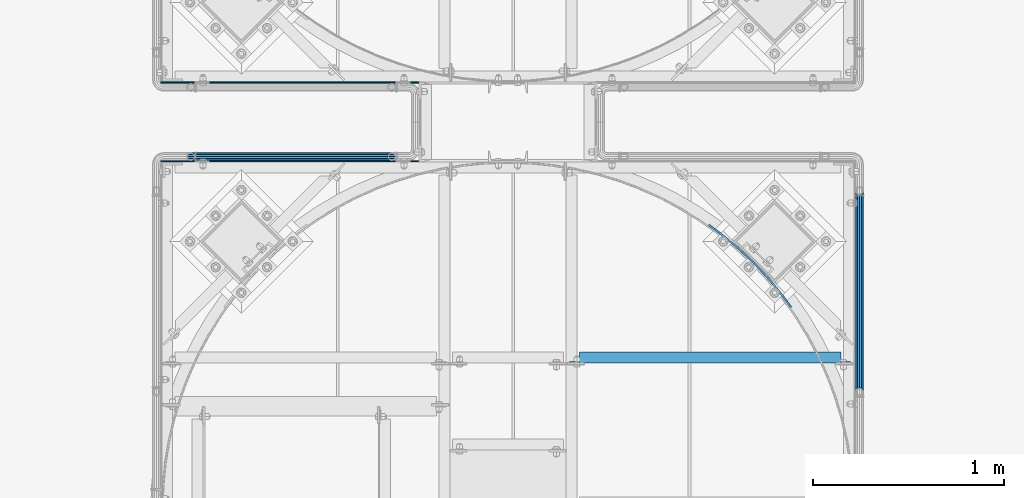
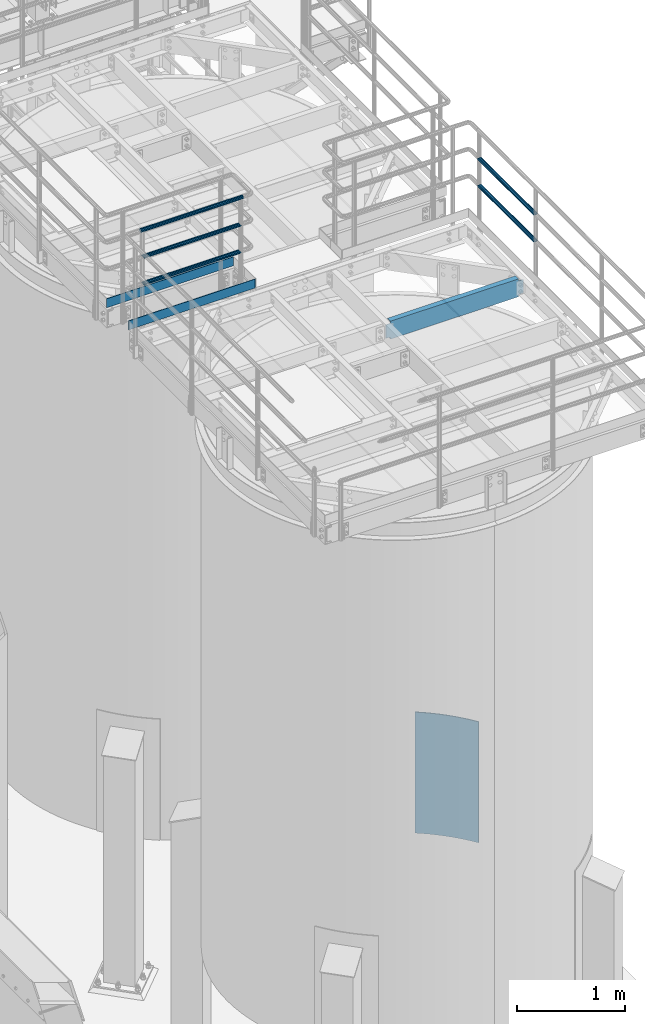
# One storey, part 925 of 1876: 9 beams, 5 elements without a shape of their own.
"""IFC2X3 building model written with IfcOpenShell, lengths in millimetres."""

from ifc_helpers import new_model, si_unit, frame, origin_with_axes, place, context, subcontext, project, spatial, faceted_brep, material, type_object, element, aggregate, save


model = new_model("IFC2X3")

# Units and contexts
model_context = context("Model", 3, precision=1e-05, world=origin_with_axes())
body_context = subcontext(model_context, "Body", "Model", "MODEL_VIEW")
ifc_project = project(units=[si_unit("LENGTHUNIT", "METRE", prefix="MILLI"), si_unit("AREAUNIT", "SQUARE_METRE"), si_unit("VOLUMEUNIT", "CUBIC_METRE"), si_unit("MASSUNIT", "GRAM", prefix="KILO"), si_unit("TIMEUNIT", "SECOND"), si_unit("PLANEANGLEUNIT", "RADIAN"), si_unit("SOLIDANGLEUNIT", "STERADIAN"), si_unit("THERMODYNAMICTEMPERATUREUNIT", "DEGREE_CELSIUS"), si_unit("LUMINOUSINTENSITYUNIT", "LUMEN")], contexts=[model_context])

# Site, building, storey
site_placement = place(None, origin_with_axes())
site = spatial("IfcSite", under=ifc_project, at=site_placement, CompositionType="ELEMENT")
building_placement = place(site_placement, origin_with_axes())
building = spatial("IfcBuilding", under=site, at=building_placement, Name="Undefined", CompositionType="ELEMENT")
storey_placement = place(building_placement, origin_with_axes())
storey = spatial("IfcBuildingStorey", under=building, at=storey_placement, Name="Undefined", CompositionType="ELEMENT", Elevation=0.0)

# Assembly, beams
assembly_1_placement = place(storey_placement, origin_with_axes())
assembly_1 = element("IfcElementAssembly", 1, at=assembly_1_placement, inside=storey, Name="HANDRAIL", AssemblyPlace="NOTDEFINED", PredefinedType="RIGID_FRAME")
ifc_material_1 = material()
beam_type_1 = type_object("IfcBeamType", Name="PIPE1-1/4STD", PredefinedType="NOTDEFINED")
beam_1_placement = place(assembly_1_placement, frame((4572.00143150122, -11745.4324531238, 8480.425), z_axis=(0.0, 0.0, 1.0), x_axis=(-1.0, 0.0, 0.0)))
beam_1 = element("IfcBeam", 2, at=beam_1_placement, type_object=beam_type_1, material=ifc_material_1, Name="RAIL", ObjectType="PIPE1-1/4STD", context=body_context, shape_type="Brep", body=[
    faceted_brep([(1035.84245243742, -10.5409999999993, 18.2575475625836), (1035.84245243742, -10.5409999999993, 13.3999612267253), (1035.36603877327, -8.76300000000083, 15.1779612267255), (1033.018, 0.0, 17.5259999999998), (1033.018, 0.0, 21.0820000000003), (1035.36603877327, 8.76300000000083, 15.1779612267255), (1035.84245243742, 10.5409999999993, 13.3999612267253), (1035.84245243742, 10.5409999999993, 18.2575475625836), (1054.1, 21.0820000000003, 0.0), (1043.559, 18.2575475625836, 10.5409999999993), (1043.559, 18.2575475625836, -10.5409999999993), (1040.47941366414, 15.1779612267255, 8.76300000000083), (1042.82745243742, 17.5259999999998, 0.0), (1040.47941366414, 15.1779612267255, -8.76300000000083), (1035.84245243742, 10.5409999999993, -13.3999612267253), (1035.84245243742, 10.5409999999993, -18.2575475625836), (1035.36603877327, 8.76300000000083, -15.1779612267255), (1033.018, 0.0, -17.5259999999998), (1033.018, 0.0, -21.0820000000003), (1035.84245243742, -10.5409999999993, -13.3999612267253), (1035.84245243742, -10.5409999999993, -18.2575475625836), (1035.36603877327, -8.76300000000083, -15.1779612267255), (1054.1, -21.0820000000003, 0.0), (1043.559, -18.2575475625836, -10.5409999999993), (1043.559, -18.2575475625836, 10.5409999999993), (1040.47941366414, -15.1779612267255, -8.76300000000083), (1042.82745243742, -17.5259999999998, 0.0), (1040.47941366414, -15.1779612267255, 8.76300000000083), (10.5409999957128, -18.2575475672238, -10.5409999999993), (18.2575475625817, -10.5410000000011, -18.2575475625836), (9.09494701772928e-13, 21.0820000000003, 0.0), (10.5409999957128, 18.2575475579433, -10.5409999999993), (10.5409999999983, 18.2575475625836, 10.5410000000011), (18.2575475625817, 10.5409999999993, 18.2575475625836), (21.0819999999985, 1.81898940354586e-12, 21.0820000000003), (18.2575475625817, 10.5409999999993, -18.2575475625836), (21.0819999999985, 0.0, -21.0819999999985), (21.0819999999985, 0.0, -17.5259999999998), (18.2575475625817, -10.5409999999974, -13.3999612267271), (18.7339612267233, -8.76300000000083, -15.1779612267255), (18.7339612267251, 8.76299999999901, -15.1779612267255), (18.2575475625817, 10.5410000000011, -13.3999612267235), (13.6205863358573, 15.1779612267255, -8.76299999999901), (11.2725475625839, 17.5259999999998, 0.0), (13.6205863358573, 15.1779612267255, 8.76300000000083), (18.2575475625817, 10.5410000000011, 13.3999612267253), (18.7339612267251, 8.76299999999901, 15.1779612267273), (21.0819999999985, 1.81898940354586e-12, 17.5259999999998), (18.7339612267233, -8.76300000000083, 15.1779612267273), (18.2575475625817, -10.5409999999974, 13.3999612267289), (18.2575475625817, -10.5410000000011, 18.2575475625836), (10.5409999999983, -18.2575475625836, 10.5410000000011), (9.09494701772928e-13, -21.0820000000003, 0.0), (13.6205863358537, -15.1779612267255, 8.76300000000083), (11.2725475625793, -17.5259999999998, 0.0), (13.6205863358537, -15.1779612267255, -8.76299999999901)], [[[0, 1, 2, 3, 4]], [[4, 3, 5, 6, 7]], [[8, 9, 10]], [[7, 6, 11, 12, 13, 14, 15, 10, 9]], [[16, 17, 18, 15, 14]], [[19, 20, 18, 17, 21]], [[22, 23, 24]], [[24, 23, 20, 19, 25, 26, 27, 1, 0]], [[28, 29, 20, 23]], [[30, 31, 32]], [[33, 34, 4, 7]], [[32, 33, 7, 9]], [[30, 32, 9, 8]], [[31, 30, 8, 10]], [[35, 31, 10, 15]], [[36, 35, 15, 18]], [[29, 36, 18, 20]], [[37, 36, 29, 38, 39]], [[40, 41, 35, 36, 37]], [[32, 31, 35, 41, 42, 43, 44, 45, 33]], [[33, 45, 46, 47, 34]], [[34, 47, 48, 49, 50]], [[34, 50, 0, 4]], [[50, 51, 24, 0]], [[51, 52, 22, 24]], [[52, 28, 23, 22]], [[51, 28, 52]], [[50, 49, 53, 54, 55, 38, 29, 28, 51]], [[55, 54, 26, 25]], [[21, 39, 38, 55, 25, 19]], [[37, 39, 21, 17]], [[40, 37, 17, 16]], [[42, 41, 40, 16, 14, 13]], [[43, 42, 13, 12]], [[44, 43, 12, 11]], [[5, 46, 45, 44, 11, 6]], [[47, 46, 5, 3]], [[48, 47, 3, 2]], [[53, 49, 48, 2, 1, 27]], [[54, 53, 27, 26]]]),
])
beam_2_placement = place(assembly_1_placement, frame((3517.90143150121, -11745.4324531238, 8785.225), z_axis=(0.0, 0.0, -1.0), x_axis=(1.0, 0.0, 0.0)))
beam_2 = element("IfcBeam", 3, at=beam_2_placement, type_object=beam_type_1, material=ifc_material_1, Name="RAIL", ObjectType="PIPE1-1/4STD", context=body_context, shape_type="Brep", body=[
    faceted_brep([(9.09494701772928e-13, 21.0820000000003, 0.0), (10.5409999957128, 18.2575475579433, -10.5409999999993), (10.5409999999983, 18.2575475625836, 10.5410000000011), (10.5409999999983, -18.2575475625836, 10.5410000000011), (10.5409999957128, -18.2575475672238, -10.5409999999993), (9.09494701772928e-13, -21.0820000000003, 0.0), (18.2575475625817, -10.5410000000011, 18.2575475625836), (18.2575475625817, -10.5409999999974, 13.3999612267289), (13.6205863358537, -15.1779612267255, 8.76300000000083), (11.2725475625793, -17.5259999999998, 0.0), (13.6205863358537, -15.1779612267255, -8.76299999999901), (18.2575475625817, -10.5409999999974, -13.3999612267271), (18.2575475625817, -10.5410000000011, -18.2575475625836), (21.0819999999985, 0.0, -17.5259999999998), (21.0819999999985, 0.0, -21.0819999999985), (18.7339612267233, -8.76300000000083, -15.1779612267255), (18.7339612267251, 8.76299999999901, -15.1779612267255), (18.2575475625817, 10.5410000000011, -13.3999612267235), (18.2575475625817, 10.5409999999993, -18.2575475625836), (13.6205863358573, 15.1779612267255, -8.76299999999901), (11.2725475625839, 17.5259999999998, 0.0), (13.6205863358573, 15.1779612267255, 8.76300000000083), (18.2575475625817, 10.5410000000011, 13.3999612267253), (18.2575475625817, 10.5409999999993, 18.2575475625836), (18.7339612267251, 8.76299999999901, 15.1779612267273), (21.0819999999985, 1.81898940354586e-12, 17.5259999999998), (21.0819999999985, 1.81898940354586e-12, 21.0820000000003), (18.7339612267233, -8.76300000000083, 15.1779612267273), (1054.1, 21.0820000000003, 0.0), (1043.559, 18.2575475625836, -10.5409999999993), (1035.84245243742, 10.5409999999993, -18.2575475625836), (1054.1, -21.0820000000003, 0.0), (1043.559, -18.2575475625836, -10.5409999999993), (1043.559, -18.2575475625836, 10.5409999999993), (1035.84245243742, -10.5409999999993, 18.2575475625836), (1035.84245243742, -10.5409999999993, -18.2575475625836), (1033.018, 0.0, -21.0820000000003), (1035.36603877327, 8.76300000000083, -15.1779612267255), (1033.018, 0.0, -17.5259999999998), (1035.84245243742, 10.5409999999993, -13.3999612267253), (1035.84245243742, -10.5409999999993, -13.3999612267253), (1035.36603877327, -8.76300000000083, -15.1779612267255), (1040.47941366414, -15.1779612267255, -8.76300000000083), (1042.82745243742, -17.5259999999998, 0.0), (1040.47941366414, -15.1779612267255, 8.76300000000083), (1035.84245243742, -10.5409999999993, 13.3999612267253), (1035.36603877327, -8.76300000000083, 15.1779612267255), (1033.018, 0.0, 17.5259999999998), (1033.018, 0.0, 21.0820000000003), (1035.84245243742, 10.5409999999993, 18.2575475625836), (1043.559, 18.2575475625836, 10.5409999999993), (1035.84245243742, 10.5409999999993, 13.3999612267253), (1040.47941366414, 15.1779612267255, 8.76300000000083), (1042.82745243742, 17.5259999999998, 0.0), (1040.47941366414, 15.1779612267255, -8.76300000000083), (1035.36603877327, 8.76300000000083, 15.1779612267255)], [[[0, 1, 2]], [[3, 4, 5]], [[6, 7, 8, 9, 10, 11, 12, 4, 3]], [[13, 14, 12, 11, 15]], [[16, 17, 18, 14, 13]], [[2, 1, 18, 17, 19, 20, 21, 22, 23]], [[23, 22, 24, 25, 26]], [[26, 25, 27, 7, 6]], [[1, 0, 28, 29]], [[18, 1, 29, 30]], [[31, 32, 33]], [[6, 3, 33, 34]], [[3, 5, 31, 33]], [[5, 4, 32, 31]], [[4, 12, 35, 32]], [[12, 14, 36, 35]], [[14, 18, 30, 36]], [[37, 38, 36, 30, 39]], [[40, 35, 36, 38, 41]], [[33, 32, 35, 40, 42, 43, 44, 45, 34]], [[34, 45, 46, 47, 48]], [[26, 6, 34, 48]], [[2, 23, 49, 50]], [[23, 26, 48, 49]], [[0, 2, 50, 28]], [[28, 50, 29]], [[49, 51, 52, 53, 54, 39, 30, 29, 50]], [[48, 47, 55, 51, 49]], [[25, 24, 55, 47]], [[55, 24, 22, 21, 52, 51]], [[21, 20, 53, 52]], [[20, 19, 54, 53]], [[19, 17, 16, 37, 39, 54]], [[16, 13, 38, 37]], [[13, 15, 41, 38]], [[41, 15, 11, 10, 42, 40]], [[10, 9, 43, 42]], [[9, 8, 44, 43]], [[8, 7, 27, 46, 45, 44]], [[27, 25, 47, 46]]]),
])
beam_3_placement = place(assembly_1_placement, frame((3496.81943150122, -11745.4324531238, 9090.025), z_axis=(0.0, 0.0, -1.0), x_axis=(1.0, 0.0, 0.0)))
beam_3 = element("IfcBeam", 4, at=beam_3_placement, type_object=beam_type_1, material=ifc_material_1, Name="HANDRAIL", ObjectType="PIPE1-1/4STD", context=body_context, shape_type="Brep", body=[
    faceted_brep([(0.0, -17.5259999999998, 0.0), (0.0, -15.1779612267264, 8.76300000000083), (1096.264, -15.1779612267255, 8.76300000000083), (1096.264, -17.5259999999998, 0.0), (0.0, -8.76299999999992, 15.1779612267255), (1096.264, -8.76300000000083, 15.1779612267255), (0.0, 0.0, 17.5259999999998), (1096.264, 0.0, 17.5259999999998), (0.0, 8.76299999999992, 15.1779612267255), (1096.264, 8.76300000000083, 15.1779612267255), (0.0, 15.1779612267264, 8.76300000000083), (1096.264, 15.1779612267255, 8.76300000000083), (0.0, 17.5259999999998, 0.0), (1096.264, 17.5259999999998, 0.0), (0.0, 15.1779612267264, -8.76300000000083), (1096.264, 15.1779612267255, -8.76300000000083), (0.0, 8.76299999999992, -15.1779612267255), (1096.264, 8.76300000000083, -15.1779612267255), (0.0, 0.0, -17.5259999999998), (1096.264, 0.0, -17.5259999999998), (0.0, -8.76299999999992, -15.1779612267255), (1096.264, -8.76300000000083, -15.1779612267255), (0.0, -15.1779612267264, -8.76300000000083), (1096.264, -15.1779612267255, -8.76300000000083), (9.09494701772928e-13, -21.0820000000003, 0.0), (0.0, -18.2575475625836, -10.5409999999993), (1096.264, -18.2575475625836, -10.5409999999993), (1096.264, -21.0820000000003, 0.0), (0.0, -10.5410000000002, -18.2575475625836), (1096.264, -10.5409999999993, -18.2575475625836), (-4.28826751885936e-09, 0.0, -21.0820000000003), (1096.264, 0.0, -21.0820000000003), (0.0, 10.5410000000002, -18.2575475625836), (1096.264, 10.5409999999993, -18.2575475625836), (0.0, 18.2575475625836, -10.5409999999993), (1096.264, 18.2575475625836, -10.5409999999993), (9.09494701772928e-13, 21.0820000000003, 0.0), (1096.264, 21.0820000000003, 0.0), (0.0, 18.2575475625836, 10.5409999999993), (1096.264, 18.2575475625836, 10.5409999999993), (0.0, 10.5410000000002, 18.2575475625836), (1096.264, 10.5409999999993, 18.2575475625836), (0.0, 0.0, 21.0820000000003), (1096.264, 0.0, 21.0820000000003), (0.0, -10.5410000000002, 18.2575475625836), (1096.264, -10.5409999999993, 18.2575475625836), (0.0, -18.2575475625836, 10.5409999999993), (1096.264, -18.2575475625836, 10.5409999999993)], [[[0, 1, 2, 3]], [[1, 4, 5, 2]], [[4, 6, 7, 5]], [[6, 8, 9, 7]], [[8, 10, 11, 9]], [[10, 12, 13, 11]], [[12, 14, 15, 13]], [[14, 16, 17, 15]], [[16, 18, 19, 17]], [[18, 20, 21, 19]], [[20, 22, 23, 21]], [[22, 0, 3, 23]], [[24, 25, 26, 27]], [[25, 28, 29, 26]], [[28, 30, 31, 29]], [[30, 32, 33, 31]], [[32, 34, 35, 33]], [[34, 36, 37, 35]], [[36, 38, 39, 37]], [[38, 40, 41, 39]], [[40, 42, 43, 41]], [[42, 44, 45, 43]], [[44, 46, 47, 45]], [[46, 24, 27, 47]], [[29, 31, 33, 35, 37, 39, 41, 43, 45, 47, 27, 26], [5, 7, 9, 11, 13, 15, 17, 19, 21, 23, 3, 2]], [[46, 44, 42, 40, 38, 36, 34, 32, 30, 28, 25, 24], [22, 20, 18, 16, 14, 12, 10, 8, 6, 4, 1, 0]]]),
])

assembly_2_placement = place(storey_placement, origin_with_axes())
assembly_2 = element("IfcElementAssembly", 5, at=assembly_2_placement, inside=storey, Name="HANDRAIL", AssemblyPlace="NOTDEFINED", PredefinedType="RIGID_FRAME")
beam_4_placement = place(assembly_2_placement, frame((7025.13056849878, -12979.3644042969, 8480.425), z_axis=(0.0, 0.0, 1.0), x_axis=(0.0, 1.0, 0.0)))
beam_4 = element("IfcBeam", 6, at=beam_4_placement, type_object=beam_type_1, material=ifc_material_1, Name="RAIL", ObjectType="PIPE1-1/4STD", context=body_context, shape_type="Brep", body=[
    faceted_brep([(1035.84245243742, -10.5409999999993, 18.2575475625836), (1035.84245243742, -10.5409999999993, 13.3999612267253), (1035.36603877327, -8.76300000000083, 15.1779612267255), (1033.018, 0.0, 17.5259999999998), (1033.018, 0.0, 21.0820000000003), (1035.36603877327, 8.76300000000083, 15.1779612267255), (1035.84245243742, 10.5409999999993, 13.3999612267253), (1035.84245243742, 10.5409999999993, 18.2575475625836), (1054.1, 21.0820000000003, 0.0), (1043.559, 18.2575475625836, 10.5409999999993), (1043.559, 18.2575475625836, -10.5409999999993), (1040.47941366414, 15.1779612267255, 8.76300000000083), (1042.82745243742, 17.5259999999998, 0.0), (1040.47941366414, 15.1779612267255, -8.76300000000083), (1035.84245243742, 10.5409999999993, -13.3999612267253), (1035.84245243742, 10.5409999999993, -18.2575475625836), (1035.36603877327, 8.76300000000083, -15.1779612267255), (1033.018, 0.0, -17.5259999999998), (1033.018, 0.0, -21.0820000000003), (1035.84245243742, -10.5409999999993, -13.3999612267253), (1035.84245243742, -10.5409999999993, -18.2575475625836), (1035.36603877327, -8.76300000000083, -15.1779612267255), (1054.1, -21.0820000000003, 0.0), (1043.559, -18.2575475625836, -10.5409999999993), (1043.559, -18.2575475625836, 10.5409999999993), (1040.47941366414, -15.1779612267255, -8.76300000000083), (1042.82745243742, -17.5259999999998, 0.0), (1040.47941366414, -15.1779612267255, 8.76300000000083), (10.5409999957128, -18.2575475672238, -10.5409999999993), (18.2575475625817, -10.5410000000011, -18.2575475625836), (9.09494701772928e-13, 21.0820000000003, 0.0), (10.5409999957128, 18.2575475579433, -10.5409999999993), (10.5409999999983, 18.2575475625836, 10.5410000000011), (18.2575475625817, 10.5409999999993, 18.2575475625836), (21.0819999999985, 1.81898940354586e-12, 21.0820000000003), (18.2575475625817, 10.5409999999993, -18.2575475625836), (21.0819999999985, 0.0, -21.0819999999985), (21.0819999999985, 0.0, -17.5259999999998), (18.2575475625817, -10.5409999999974, -13.3999612267271), (18.7339612267233, -8.76300000000083, -15.1779612267255), (18.7339612267251, 8.76299999999901, -15.1779612267255), (18.2575475625817, 10.5410000000011, -13.3999612267235), (13.6205863358573, 15.1779612267255, -8.76299999999901), (11.2725475625839, 17.5259999999998, 0.0), (13.6205863358573, 15.1779612267255, 8.76300000000083), (18.2575475625817, 10.5410000000011, 13.3999612267253), (18.7339612267251, 8.76299999999901, 15.1779612267273), (21.0819999999985, 1.81898940354586e-12, 17.5259999999998), (18.7339612267233, -8.76300000000083, 15.1779612267273), (18.2575475625817, -10.5409999999974, 13.3999612267289), (18.2575475625817, -10.5410000000011, 18.2575475625836), (10.5409999999983, -18.2575475625836, 10.5410000000011), (9.09494701772928e-13, -21.0820000000003, 0.0), (13.6205863358537, -15.1779612267255, 8.76300000000083), (11.2725475625793, -17.5259999999998, 0.0), (13.6205863358537, -15.1779612267255, -8.76299999999901)], [[[0, 1, 2, 3, 4]], [[4, 3, 5, 6, 7]], [[8, 9, 10]], [[7, 6, 11, 12, 13, 14, 15, 10, 9]], [[16, 17, 18, 15, 14]], [[19, 20, 18, 17, 21]], [[22, 23, 24]], [[24, 23, 20, 19, 25, 26, 27, 1, 0]], [[28, 29, 20, 23]], [[30, 31, 32]], [[33, 34, 4, 7]], [[32, 33, 7, 9]], [[30, 32, 9, 8]], [[31, 30, 8, 10]], [[35, 31, 10, 15]], [[36, 35, 15, 18]], [[29, 36, 18, 20]], [[37, 36, 29, 38, 39]], [[40, 41, 35, 36, 37]], [[32, 31, 35, 41, 42, 43, 44, 45, 33]], [[33, 45, 46, 47, 34]], [[34, 47, 48, 49, 50]], [[34, 50, 0, 4]], [[50, 51, 24, 0]], [[51, 52, 22, 24]], [[52, 28, 23, 22]], [[51, 28, 52]], [[50, 49, 53, 54, 55, 38, 29, 28, 51]], [[55, 54, 26, 25]], [[21, 39, 38, 55, 25, 19]], [[37, 39, 21, 17]], [[40, 37, 17, 16]], [[42, 41, 40, 16, 14, 13]], [[43, 42, 13, 12]], [[44, 43, 12, 11]], [[5, 46, 45, 44, 11, 6]], [[47, 46, 5, 3]], [[48, 47, 3, 2]], [[53, 49, 48, 2, 1, 27]], [[54, 53, 27, 26]]]),
])
beam_5_placement = place(assembly_2_placement, frame((7025.13056849878, -11925.2644042969, 8785.225), z_axis=(0.0, 0.0, -1.0), x_axis=(0.0, -1.0, 0.0)))
beam_5 = element("IfcBeam", 7, at=beam_5_placement, type_object=beam_type_1, material=ifc_material_1, Name="RAIL", ObjectType="PIPE1-1/4STD", context=body_context, shape_type="Brep", body=[
    faceted_brep([(9.09494701772928e-13, 21.0820000000003, 0.0), (10.5409999957128, 18.2575475579433, -10.5409999999993), (10.5409999999983, 18.2575475625836, 10.5410000000011), (10.5409999999983, -18.2575475625836, 10.5410000000011), (10.5409999957128, -18.2575475672238, -10.5409999999993), (9.09494701772928e-13, -21.0820000000003, 0.0), (18.2575475625817, -10.5410000000011, 18.2575475625836), (18.2575475625817, -10.5409999999974, 13.3999612267289), (13.6205863358537, -15.1779612267255, 8.76300000000083), (11.2725475625793, -17.5259999999998, 0.0), (13.6205863358537, -15.1779612267255, -8.76299999999901), (18.2575475625817, -10.5409999999974, -13.3999612267271), (18.2575475625817, -10.5410000000011, -18.2575475625836), (21.0819999999985, 0.0, -17.5259999999998), (21.0819999999985, 0.0, -21.0819999999985), (18.7339612267233, -8.76300000000083, -15.1779612267255), (18.7339612267251, 8.76299999999901, -15.1779612267255), (18.2575475625817, 10.5410000000011, -13.3999612267235), (18.2575475625817, 10.5409999999993, -18.2575475625836), (13.6205863358573, 15.1779612267255, -8.76299999999901), (11.2725475625839, 17.5259999999998, 0.0), (13.6205863358573, 15.1779612267255, 8.76300000000083), (18.2575475625817, 10.5410000000011, 13.3999612267253), (18.2575475625817, 10.5409999999993, 18.2575475625836), (18.7339612267251, 8.76299999999901, 15.1779612267273), (21.0819999999985, 1.81898940354586e-12, 17.5259999999998), (21.0819999999985, 1.81898940354586e-12, 21.0820000000003), (18.7339612267233, -8.76300000000083, 15.1779612267273), (1054.1, 21.0820000000003, 0.0), (1043.559, 18.2575475625836, -10.5409999999993), (1035.84245243742, 10.5409999999993, -18.2575475625836), (1054.1, -21.0820000000003, 0.0), (1043.559, -18.2575475625836, -10.5409999999993), (1043.559, -18.2575475625836, 10.5409999999993), (1035.84245243742, -10.5409999999993, 18.2575475625836), (1035.84245243742, -10.5409999999993, -18.2575475625836), (1033.018, 0.0, -21.0820000000003), (1035.36603877327, 8.76300000000083, -15.1779612267255), (1033.018, 0.0, -17.5259999999998), (1035.84245243742, 10.5409999999993, -13.3999612267253), (1035.84245243742, -10.5409999999993, -13.3999612267253), (1035.36603877327, -8.76300000000083, -15.1779612267255), (1040.47941366414, -15.1779612267255, -8.76300000000083), (1042.82745243742, -17.5259999999998, 0.0), (1040.47941366414, -15.1779612267255, 8.76300000000083), (1035.84245243742, -10.5409999999993, 13.3999612267253), (1035.36603877327, -8.76300000000083, 15.1779612267255), (1033.018, 0.0, 17.5259999999998), (1033.018, 0.0, 21.0820000000003), (1035.84245243742, 10.5409999999993, 18.2575475625836), (1043.559, 18.2575475625836, 10.5409999999993), (1035.84245243742, 10.5409999999993, 13.3999612267253), (1040.47941366414, 15.1779612267255, 8.76300000000083), (1042.82745243742, 17.5259999999998, 0.0), (1040.47941366414, 15.1779612267255, -8.76300000000083), (1035.36603877327, 8.76300000000083, 15.1779612267255)], [[[0, 1, 2]], [[3, 4, 5]], [[6, 7, 8, 9, 10, 11, 12, 4, 3]], [[13, 14, 12, 11, 15]], [[16, 17, 18, 14, 13]], [[2, 1, 18, 17, 19, 20, 21, 22, 23]], [[23, 22, 24, 25, 26]], [[26, 25, 27, 7, 6]], [[1, 0, 28, 29]], [[18, 1, 29, 30]], [[31, 32, 33]], [[6, 3, 33, 34]], [[3, 5, 31, 33]], [[5, 4, 32, 31]], [[4, 12, 35, 32]], [[12, 14, 36, 35]], [[14, 18, 30, 36]], [[37, 38, 36, 30, 39]], [[40, 35, 36, 38, 41]], [[33, 32, 35, 40, 42, 43, 44, 45, 34]], [[34, 45, 46, 47, 48]], [[26, 6, 34, 48]], [[2, 23, 49, 50]], [[23, 26, 48, 49]], [[0, 2, 50, 28]], [[28, 50, 29]], [[49, 51, 52, 53, 54, 39, 30, 29, 50]], [[48, 47, 55, 51, 49]], [[25, 24, 55, 47]], [[55, 24, 22, 21, 52, 51]], [[21, 20, 53, 52]], [[20, 19, 54, 53]], [[19, 17, 16, 37, 39, 54]], [[16, 13, 38, 37]], [[13, 15, 41, 38]], [[41, 15, 11, 10, 42, 40]], [[10, 9, 43, 42]], [[9, 8, 44, 43]], [[8, 7, 27, 46, 45, 44]], [[27, 25, 47, 46]]]),
])
aggregate(assembly_2, [beam_4, beam_5])

# Assembly, beam
assembly_3_placement = place(storey_placement, origin_with_axes())
assembly_3 = element("IfcElementAssembly", 8, at=assembly_3_placement, inside=storey, Name="HANDRAIL", AssemblyPlace="NOTDEFINED", PredefinedType="RIGID_FRAME")
ifc_material_2 = material(Name="STEEL/A36")
beam_type_2 = type_object("IfcBeamType", PredefinedType="NOTDEFINED")
beam_6_placement = place(assembly_3_placement, frame((3359.15806037402, -11356.9393554687, 8080.375), z_axis=(0.0, 0.0, 1.0), x_axis=(1.0, 0.0, 0.0)))
beam_6 = element("IfcBeam", 9, at=beam_6_placement, type_object=beam_type_2, material=ifc_material_2, Name="PLATE", context=body_context, shape_type="Brep", body=[
    faceted_brep([(1358.89337112719, -3.17499999999927, -50.8000000000002), (1352.5433711272, 3.17499999999927, -50.8000000000002), (1352.5433711272, 3.17499999999927, 50.8000000000002), (1358.89337112719, -3.17499999999927, 50.8000000000002), (0.0, 3.17500000000018, -50.8000000000002), (0.0, 3.17500000000018, 50.8000000000002), (0.0, -3.17500000000018, 50.8000000000002), (0.0, -3.17500000000018, -50.8000000000002)], [[[0, 1, 2, 3]], [[4, 5, 2, 1]], [[5, 6, 3, 2]], [[6, 7, 0, 3]], [[7, 4, 1, 0]], [[7, 6, 5, 4]]]),
])
aggregate(assembly_3, [beam_6])

# Beam
beam_7_placement = place(assembly_1_placement, frame((3359.15143150122, -11769.6894531238, 8080.375), z_axis=(0.0, 0.0, 1.0), x_axis=(1.0, 0.0, 0.0)))
beam_7 = element("IfcBeam", 10, at=beam_7_placement, type_object=beam_type_2, material=ifc_material_2, Name="PLATE", context=body_context, shape_type="Brep", body=[
    faceted_brep([(1352.55, -3.17499999999927, -50.8000000000002), (1358.9, 3.17499999999927, -50.8000000000002), (1358.9, 3.17499999999927, 50.8000000000002), (1352.55, -3.17499999999927, 50.8000000000002), (0.0, 3.17500000000018, -50.8000000000002), (0.0, 3.17500000000018, 50.8000000000002), (0.0, -3.17500000000018, 50.8000000000002), (0.0, -3.17500000000018, -50.8000000000002)], [[[0, 1, 2, 3]], [[4, 5, 2, 1]], [[5, 6, 3, 2]], [[6, 7, 0, 3]], [[7, 4, 1, 0]], [[7, 6, 5, 4]]]),
])

aggregate(assembly_1, [beam_7, beam_1, beam_2, beam_3])

# Assembly, beam
assembly_4_placement = place(storey_placement, origin_with_axes())
assembly_4 = element("IfcElementAssembly", 11, at=assembly_4_placement, inside=storey, Name="BEAM", AssemblyPlace="NOTDEFINED", PredefinedType="RIGID_FRAME")
beam_type_3 = type_object("IfcBeamType", Name="C8X11.5", PredefinedType="NOTDEFINED")
beam_8_placement = place(assembly_4_placement, frame((5486.40143150122, -12798.3894042969, 7896.225), z_axis=(0.0, 0.0, -1.0), x_axis=(1.0, 0.0, 0.0)))
beam_8 = element("IfcBeam", 12, at=beam_8_placement, type_object=beam_type_3, material=ifc_material_2, Name="BEAM", ObjectType="C8X11.5", context=body_context, shape_type="Brep", body=[
    faceted_brep([(1441.44713699756, -28.5750000000007, -96.8355949999996), (1441.44713699756, -28.5750000000007, -101.6), (1441.44713699756, 28.5750000000007, -101.6), (1441.44713699756, 28.5750000000007, -88.899999809264), (1441.44713699756, 19.0576241940926, -88.899999809264), (1441.5521000322, 22.2250000000004, -88.3723149999996), (1442.41386692015, 28.5750000000007, -84.0399202912186), (1442.41386692015, 22.2250000000004, -84.0399202912186), (1445.16688082063, 28.5750000000007, -79.9197438230649), (1445.16688082063, 22.2250000000004, -79.9197438230649), (1449.28705728878, 28.5750000000007, -77.1667299225865), (1449.28705728878, 22.2250000000004, -77.1667299225865), (1454.14713680683, 28.5750000000007, -76.1999999999989), (1454.14713680683, 22.2250000000004, -76.1999999999989), (1492.24713699756, 22.2250000000004, -76.1999999999989), (1492.24713699756, 28.5750000000007, -76.1999999999989), (1441.44713699756, -28.5750000000007, 101.6), (1441.44713699756, 28.5750000000007, 101.6), (69.8500000000013, 28.5750000000007, 101.6), (69.8500000000013, -28.5750000000007, 101.6), (69.8500000000013, 19.0576241940817, -88.8999998092659), (69.8500000000013, 28.5750000000007, -88.8999998092659), (69.8500000000013, 28.5750000000007, -101.6), (69.8500000000013, -28.5750000000007, -101.6), (69.8500000000013, -28.5750000000007, -96.8355949999996), (69.7450369653598, 22.2250000000004, -88.3723149999996), (68.8832700774137, 22.2250000000004, -84.0399202912204), (68.8832700774137, 28.5750000000007, -84.0399202912204), (66.1302561769353, 22.2250000000004, -79.9197438230667), (66.1302561769353, 28.5750000000007, -79.9197438230667), (62.0100797087816, 22.2250000000004, -77.1667299225883), (62.0100797087816, 28.5750000000007, -77.1667299225883), (57.1500001907361, 22.2250000000004, -76.2000000000007), (57.1500001907361, 28.5750000000007, -76.2000000000007), (19.0499999999993, 22.2250000000004, -76.2000000000007), (19.0499999999993, 28.5750000000007, -76.2000000000007), (19.0499999999993, 22.2250000000004, 76.1999999999989), (19.0499999999993, 28.5750000000007, 76.1999999999989), (57.1500001907361, 22.2250000000004, 76.1999999999989), (57.1500001907361, 28.5750000000007, 76.1999999999989), (62.0100797087816, 22.2250000000004, 77.1667299225865), (62.0100797087816, 28.5750000000007, 77.1667299225865), (66.1302561769353, 22.2250000000004, 79.9197438230649), (66.1302561769353, 28.5750000000007, 79.9197438230649), (68.8832700774137, 22.2250000000004, 84.0399202912186), (68.8832700774137, 28.5750000000007, 84.0399202912186), (69.8500000000013, 19.0576241940926, 88.899999809264), (69.8500000000013, 28.5750000000007, 88.899999809264), (69.7450369653607, 22.2250000000004, 88.3723149999996), (69.8500000000013, -28.5750000000007, 96.8355949999996), (1441.44713699756, -28.5750000000007, 96.8355949999996), (1441.44713699756, 19.0576241940817, 88.8999998092659), (1441.44713699756, 28.5750000000007, 88.8999998092659), (1441.5521000322, 22.2250000000004, 88.3723149999996), (1442.41386692015, 22.2250000000004, 84.0399202912204), (1442.41386692015, 28.5750000000007, 84.0399202912204), (1445.16688082063, 22.2250000000004, 79.9197438230667), (1445.16688082063, 28.5750000000007, 79.9197438230667), (1449.28705728878, 22.2250000000004, 77.1667299225883), (1449.28705728878, 28.5750000000007, 77.1667299225883), (1454.14713680683, 22.2250000000004, 76.2000000000007), (1454.14713680683, 28.5750000000007, 76.2000000000007), (1492.24713699756, 22.2250000000004, 76.2000000000007), (1492.24713699756, 28.5750000000007, 76.2000000000007)], [[[0, 1, 2, 3, 4]], [[5, 4, 3, 6, 7]], [[7, 6, 8, 9]], [[9, 8, 10, 11]], [[11, 10, 12, 13]], [[14, 13, 12, 15]], [[16, 17, 18, 19]], [[20, 21, 22, 23, 24]], [[25, 26, 27, 21, 20]], [[28, 29, 27, 26]], [[30, 31, 29, 28]], [[32, 33, 31, 30]], [[34, 35, 33, 32]], [[36, 37, 35, 34]], [[38, 39, 37, 36]], [[40, 41, 39, 38]], [[42, 43, 41, 40]], [[44, 45, 43, 42]], [[46, 47, 45, 44, 48]], [[19, 18, 47, 46, 49]], [[50, 16, 19, 49]], [[16, 50, 51, 52, 17]], [[48, 53, 51, 50, 49, 46]], [[54, 55, 52, 51, 53]], [[56, 57, 55, 54]], [[58, 59, 57, 56]], [[60, 61, 59, 58]], [[62, 63, 61, 60]], [[63, 62, 14, 15]], [[29, 31, 33, 35, 37, 39, 41, 43, 45, 47, 18, 17, 52, 55, 57, 59, 61, 63, 15, 12, 10, 8, 6, 3, 2, 22, 21, 27]], [[2, 1, 23, 22]], [[1, 0, 24, 23]], [[24, 0, 4, 5, 25, 20]], [[5, 7, 9, 11, 13, 14, 62, 60, 58, 56, 54, 53, 48, 44, 42, 40, 38, 36, 34, 32, 30, 28, 26, 25]]]),
])
aggregate(assembly_4, [beam_8])

assembly_5_placement = place(storey_placement, origin_with_axes())
assembly_5 = element("IfcElementAssembly", 13, at=assembly_5_placement, inside=storey, Name="COLUMN", AssemblyPlace="NOTDEFINED", PredefinedType="RIGID_FRAME")
beam_type_4 = type_object("IfcBeamType", PredefinedType="NOTDEFINED")
beam_9_placement = place(assembly_5_placement, frame((6234.7895206541, -12103.6278020889, 2209.8), z_axis=(0.0, 0.0, 1.0), x_axis=(0.707106781186547, -0.707106781186548, 0.0)))
beam_9 = element("IfcBeam", 14, at=beam_9_placement, type_object=beam_type_4, material=ifc_material_2, Name="PLATE", context=body_context, shape_type="Brep", body=[
    faceted_brep([(-0.79930179960138, 4.6949465261232, -685.8), (-0.79930179960138, 4.6949465261232, 685.8), (60.0611937621743, 14.0031633272019, 685.8), (60.0611937621743, 14.0031633272019, -685.8), (0.79930179960138, -4.6949465261232, 685.8), (0.79930179960138, -4.6949465261232, -685.8), (61.3422639062264, 4.56470559905301, -685.8), (61.3422639062264, 4.56470559905301, 685.8), (121.200950016122, 21.2538891700888, 685.8), (121.200950016122, 21.2538891700888, -685.8), (122.163029690721, 11.7776015161735, -685.8), (122.163029690721, 11.7776015161735, 685.8), (182.550430177147, 26.4388775030229, 685.8), (182.550430177147, 26.4388775030229, -685.8), (183.192425169107, 16.9355376990206, -685.8), (183.192425169107, 16.9355376990206, 685.8), (244.039858932445, 29.5522312233416, 685.8), (244.039858932445, 29.5522312233416, -685.8), (244.361039074185, 20.0326478124689, -685.8), (244.361039074185, 20.0326478124689, 685.8), (305.599301799859, 30.5904093845011, 685.8), (305.599301799859, 30.5904093845011, -685.8), (305.599301799861, 21.0654093844987, -685.8), (305.599301799861, 21.0654093844987, 685.8), (367.158744667275, 29.5522312233416, 685.8), (367.158744667275, 29.5522312233416, -685.8), (366.837564525536, 20.0326478124671, -685.8), (366.837564525536, 20.0326478124671, 685.8), (428.648173422573, 26.4388775030238, 685.8), (428.648173422573, 26.4388775030238, -685.8), (428.006178430616, 16.9355376990216, -685.8), (428.006178430616, 16.9355376990216, 685.8), (489.997653583598, 21.2538891700897, 685.8), (489.997653583598, 21.2538891700897, -685.8), (489.035573908999, 11.7776015161735, -685.8), (489.035573908999, 11.7776015161735, 685.8), (551.137409837545, 14.0031633272019, 685.8), (551.137409837545, 14.0031633272019, -685.8), (549.856339693495, 4.56470559905301, -685.8), (549.856339693495, 4.56470559905301, 685.8), (611.997905399321, 4.6949465261232, 685.8), (611.997905399321, 4.6949465261232, -685.8), (610.399301800118, -4.69494652612411, 685.8), (610.399301800118, -4.69494652612411, -685.8)], [[[0, 1, 2, 3]], [[4, 5, 6, 7]], [[5, 4, 1, 0]], [[3, 2, 8, 9]], [[7, 6, 10, 11]], [[9, 8, 12, 13]], [[11, 10, 14, 15]], [[13, 12, 16, 17]], [[15, 14, 18, 19]], [[17, 16, 20, 21]], [[19, 18, 22, 23]], [[21, 20, 24, 25]], [[23, 22, 26, 27]], [[25, 24, 28, 29]], [[27, 26, 30, 31]], [[29, 28, 32, 33]], [[31, 30, 34, 35]], [[33, 32, 36, 37]], [[35, 34, 38, 39]], [[37, 36, 40, 41]], [[36, 32, 28, 24, 20, 16, 12, 8, 2, 1, 4, 7, 11, 15, 19, 23, 27, 31, 35, 39, 42, 40]], [[39, 38, 43, 42]], [[38, 34, 30, 26, 22, 18, 14, 10, 6, 5, 0, 3, 9, 13, 17, 21, 25, 29, 33, 37, 41, 43]], [[42, 43, 41, 40]]]),
])
aggregate(assembly_5, [beam_9])

save(model, "model.ifc")
